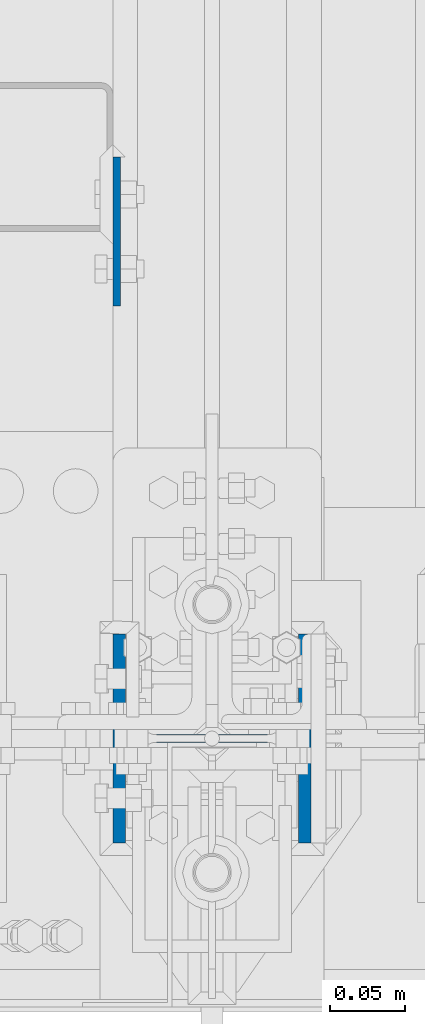
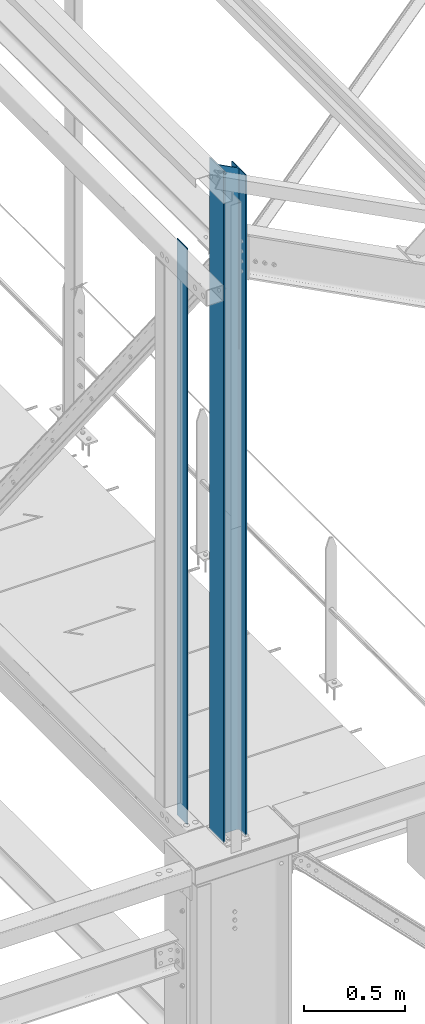
# One storey, part 2 of 496: 2 columns, 2 elements without a shape of their own.
"""IFC2X3 building model written with IfcOpenShell, lengths in millimetres."""

import ifcopenshell
import ifcopenshell.guid

model = None  # the IFC model being written
_history = None  # IfcOwnerHistory: only IFC2X3 demands one
_inside = {}  # id of a spatial element -> (the spatial element, [elements in it])
_under = {}  # id of a project, library or spatial element -> (it, [spatial elements below it])
_declared = {}  # id of a project -> (the project, [libraries it declares])
_typed = {}  # id of a type object -> (the type object, [elements of that type])
_made_of = {}  # id of a material, layer set ... -> (it, [elements and type objects made of it])


def new_model(schema):
    """Start an empty IFC model of exactly this schema.

    Asked for "IFC4X3", IfcOpenShell would pick the latest addendum, in which some entities
    have other attributes; the version numbers below select the first issue.
    IFC2X3 requires an IfcOwnerHistory on every rooted entity: one is made here for all.
    """
    global model, _history
    if schema == "IFC4X3":
        model = ifcopenshell.file(schema_version=(4, 3, 0, 0))
    else:
        model = ifcopenshell.file(schema=schema)
    _inside.clear()
    _under.clear()
    _declared.clear()
    _typed.clear()
    _made_of.clear()
    _history = None
    if model.schema == "IFC2X3":
        org = make("IfcOrganization", Name="unknown")
        user = make(
            "IfcPersonAndOrganization",
            ThePerson=make("IfcPerson", FamilyName="unknown"),
            TheOrganization=org,
        )
        app = make(
            "IfcApplication",
            ApplicationDeveloper=org,
            Version="unknown",
            ApplicationFullName="unknown",
            ApplicationIdentifier="unknown",
        )
        _history = make(
            "IfcOwnerHistory",
            OwningUser=user,
            OwningApplication=app,
            ChangeAction="ADDED",
            CreationDate=0,
        )
    return model


def make(cls, **values):
    """One entity of the class cls with the attributes given. An attribute that is None is left unset."""
    return model.create_entity(
        cls, **{name: value for name, value in values.items() if value is not None}
    )


def rooted(cls, **values):
    """An entity with a GlobalId (a new one), such as an element, a storey or a relation."""
    return make(cls, GlobalId=ifcopenshell.guid.new(), OwnerHistory=_history, **values)


def si_unit(unit_type, name, prefix=None):
    """IfcSIUnit, for example si_unit("LENGTHUNIT", "METRE", prefix="MILLI")."""
    return make("IfcSIUnit", UnitType=unit_type, Prefix=prefix, Name=name)


def assignment(units):
    """IfcUnitAssignment: the units of a project."""
    return None if units is None else make("IfcUnitAssignment", Units=units)


def point(xyz):
    """IfcCartesianPoint."""
    return None if xyz is None else make("IfcCartesianPoint", Coordinates=xyz)


def direction(xyz):
    """IfcDirection."""
    return None if xyz is None else make("IfcDirection", DirectionRatios=xyz)


def frame(location, z_axis=None, x_axis=None):
    """IfcAxis2Placement3D, a coordinate frame: its origin and axes. An axis left out is left unset."""
    return make(
        "IfcAxis2Placement3D",
        Location=point(location),
        Axis=direction(z_axis),
        RefDirection=direction(x_axis),
    )


def frame_2d(location, x_axis=None):
    """IfcAxis2Placement2D, a coordinate frame in the plane: its origin and x axis."""
    return make(
        "IfcAxis2Placement2D", Location=point(location), RefDirection=direction(x_axis)
    )


def origin_with_axes():
    """The frame at (0, 0, 0) with the z axis (0, 0, 1) and the x axis (1, 0, 0) written out."""
    return frame((0.0, 0.0, 0.0), z_axis=(0.0, 0.0, 1.0), x_axis=(1.0, 0.0, 0.0))


def origin_2d_with_axis():
    """The frame at (0, 0) in the plane with the x axis (1, 0) written out."""
    return frame_2d((0.0, 0.0), x_axis=(1.0, 0.0))


def place(relative_to, where):
    """IfcLocalPlacement: puts the frame where relative to a parent placement (None: the world)."""
    return make(
        "IfcLocalPlacement", PlacementRelTo=relative_to, RelativePlacement=where
    )


def context(
    kind, dimensions, precision=None, world=None, true_north=None, identifier=None
):
    """IfcGeometricRepresentationContext, for example the 3D "Model" context."""
    return make(
        "IfcGeometricRepresentationContext",
        ContextIdentifier=identifier,
        ContextType=kind,
        CoordinateSpaceDimension=dimensions,
        Precision=precision,
        WorldCoordinateSystem=world,
        TrueNorth=true_north,
    )


def subcontext(parent, identifier, kind, view, scale=None):
    """IfcGeometricRepresentationSubContext, for example "Body" below "Model"."""
    return make(
        "IfcGeometricRepresentationSubContext",
        ContextIdentifier=identifier,
        ContextType=kind,
        ParentContext=parent,
        TargetScale=scale,
        TargetView=view,
    )


def project(units=None, contexts=None):
    """IfcProject with its units and contexts."""
    return rooted(
        "IfcProject",
        Name="project",
        RepresentationContexts=contexts,
        UnitsInContext=assignment(units),
    )


def spatial(cls, under=None, at=None, **own):
    """A site, building, storey or space (cls), placed at a placement, below another one or the project."""
    s = rooted(cls, ObjectPlacement=at, **own)
    if under is not None:
        _under.setdefault(under.id(), (under, []))[1].append(s)
    return s


def profile(cls, at=None, kind="AREA", **sizes):
    """A parametric profile (cls). Its sizes go by their IFC names, for example OverallWidth=200.0."""
    return make(cls, ProfileType=kind, Position=at, **sizes)


def rectangle(**sizes):
    """IfcRectangleProfileDef."""
    return profile("IfcRectangleProfileDef", **sizes)


def i_section(**sizes):
    """IfcIShapeProfileDef."""
    return profile("IfcIShapeProfileDef", **sizes)


def extrude(swept, where, along, depth):
    """IfcExtrudedAreaSolid: the profile swept, set in the frame where, extruded along a direction by depth."""
    return make(
        "IfcExtrudedAreaSolid",
        SweptArea=swept,
        Position=where,
        ExtrudedDirection=direction(along),
        Depth=depth,
    )


def clip(a, b, op="DIFFERENCE"):
    """IfcBooleanClippingResult: the solid a cut by the half space b."""
    return make(
        "IfcBooleanClippingResult", Operator=op, FirstOperand=a, SecondOperand=b
    )


def halfspace(plane, agree):
    """IfcHalfSpaceSolid: all space on one side of the plane z = 0 of the frame plane."""
    return make(
        "IfcHalfSpaceSolid",
        BaseSurface=make("IfcPlane", Position=plane),
        AgreementFlag=agree,
    )


def shape(context_of_items, identifier, shape_type, items):
    """IfcShapeRepresentation: the items that make up one representation, for example the "Body"."""
    return make(
        "IfcShapeRepresentation",
        ContextOfItems=context_of_items,
        RepresentationIdentifier=identifier,
        RepresentationType=shape_type,
        Items=items,
    )


def material(Name=None, Category=None):
    """IfcMaterial."""
    return make("IfcMaterial", Name=Name, Category=Category)


def made_of(thing, what):
    """Note that an element or type object is made of a material, layer set ...; save() writes the relation."""
    if what is not None:
        _made_of.setdefault(what.id(), (what, []))[1].append(thing)
    return thing


def type_object(cls, material=None, **own):
    """A type object (cls), such as IfcWallType, which elements share."""
    return made_of(rooted(cls, **own), material)


def element(
    cls,
    number,
    at=None,
    inside=None,
    cuts=None,
    type_object=None,
    material=None,
    context=None,
    identifier="Body",
    shape_type=None,
    held_by="IfcProductDefinitionShape",
    body=None,
    shapes=None,
    **own,
):
    """One element of the class cls, such as IfcWall. Its Tag is "e" and its number.

    at: its placement. inside: the storey or other place that contains it. cuts: it is an
    opening in that element (IfcRelVoidsElement). A single representation is given by context,
    identifier, shape_type and body (its items); several are given by shapes. held_by: the class
    of the entity that holds the representations. save() writes the other relations.
    """
    e = rooted(cls, Tag="e%d" % number, ObjectPlacement=at, **own)
    if body is not None:
        shapes = [shape(context, identifier, shape_type, body)]
    if shapes is not None:
        e.Representation = make(held_by, Representations=shapes)
    if inside is not None:
        _inside.setdefault(inside.id(), (inside, []))[1].append(e)
    if cuts is not None:
        rooted(
            "IfcRelVoidsElement", RelatingBuildingElement=cuts, RelatedOpeningElement=e
        )
    if type_object is not None:
        _typed.setdefault(type_object.id(), (type_object, []))[1].append(e)
    return made_of(e, material)


def aggregate(whole, parts):
    """IfcRelAggregates: a whole, such as a stair, and the parts it consists of."""
    return rooted("IfcRelAggregates", RelatingObject=whole, RelatedObjects=parts)


def save(model, path):
    """Write the relations noted so far, then the file.

    IfcRelAggregates (storeys below a building ...), IfcRelContainedInSpatialStructure (elements
    in a storey), IfcRelDefinesByType, IfcRelAssociatesMaterial and IfcRelDeclares: one each for
    every whole, place, type object, material and project.
    """
    for whole, parts in _under.values():
        aggregate(whole, parts)
    for where, things in _inside.values():
        rooted(
            "IfcRelContainedInSpatialStructure",
            RelatedElements=things,
            RelatingStructure=where,
        )
    for kind, things in _typed.values():
        rooted("IfcRelDefinesByType", RelatedObjects=things, RelatingType=kind)
    for what, things in _made_of.values():
        rooted("IfcRelAssociatesMaterial", RelatedObjects=things, RelatingMaterial=what)
    for by, libraries in _declared.values():
        rooted("IfcRelDeclares", RelatingContext=by, RelatedDefinitions=libraries)
    model.write(path)


model = new_model("IFC2X3")

# Units and contexts
model_context = context("Model", 3, precision=1e-05, world=origin_with_axes())
body_context = subcontext(model_context, "Body", "Model", "MODEL_VIEW")
ifc_project = project(units=[si_unit("LENGTHUNIT", "METRE", prefix="MILLI"), si_unit("AREAUNIT", "SQUARE_METRE"), si_unit("VOLUMEUNIT", "CUBIC_METRE"), si_unit("MASSUNIT", "GRAM", prefix="KILO"), si_unit("TIMEUNIT", "SECOND"), si_unit("PLANEANGLEUNIT", "RADIAN"), si_unit("SOLIDANGLEUNIT", "STERADIAN"), si_unit("THERMODYNAMICTEMPERATUREUNIT", "DEGREE_CELSIUS"), si_unit("LUMINOUSINTENSITYUNIT", "LUMEN")], contexts=[model_context])

# Site, building, storey
site_placement = place(None, origin_with_axes())
site = spatial("IfcSite", under=ifc_project, at=site_placement, CompositionType="ELEMENT")
building_placement = place(site_placement, origin_with_axes())
building = spatial("IfcBuilding", under=site, at=building_placement, Name="Undefined", CompositionType="ELEMENT")
storey_placement = place(building_placement, origin_with_axes())
storey = spatial("IfcBuildingStorey", under=building, at=storey_placement, Name="Undefined", CompositionType="ELEMENT", Elevation=0.0)

# Assembly, column
assembly_1_placement = place(storey_placement, origin_with_axes())
assembly_1 = element("IfcElementAssembly", 1, at=assembly_1_placement, inside=storey, Name="MONTANT", AssemblyPlace="NOTDEFINED", PredefinedType="NOTDEFINED")
ifc_material_1 = material(Name="Undefined/S275-E28")
column_type_1 = type_object("IfcColumnType", Name="HEA140", PredefinedType="NOTDEFINED")
column_1_placement = place(assembly_1_placement, frame((12680.0, 0.0, 8560.0), z_axis=(0.0, 0.0, 1.0), x_axis=(-1.0, 0.0, 0.0)))
column_1 = element("IfcColumn", 2, at=column_1_placement, type_object=column_type_1, material=ifc_material_1, Name="MONTANT", ObjectType="HEA140", context=body_context, shape_type="Clipping", body=[
    clip(extrude(i_section(OverallWidth=140.0, OverallDepth=133.0, WebThickness=5.5, FlangeThickness=8.5, FilletRadius=12.0, at=origin_2d_with_axis()), frame((0.0, 0.0, 4053.83), z_axis=(0.0, 0.0, -1.0), x_axis=(0.0, 1.0, 0.0)), (0.0, 0.0, 1.0), 4053.83), halfspace(frame((-66.5, 70.0, 3972.97130380653), z_axis=(-0.463528461042155, -7.08866187195592e-09, 0.886082031080583), x_axis=(0.886082031080583, 0.0, 0.463528461042155)), False)),
])
aggregate(assembly_1, [column_1])

assembly_2_placement = place(storey_placement, origin_with_axes())
assembly_2 = element("IfcElementAssembly", 3, at=assembly_2_placement, inside=storey, Name="MONTANT", AssemblyPlace="NOTDEFINED", PredefinedType="NOTDEFINED")
ifc_material_2 = material(Name="Undefined/S235-E24")
column_type_2 = type_object("IfcColumnType", PredefinedType="NOTDEFINED")
column_2_placement = place(assembly_2_placement, frame((12616.000107016, 339.9999987911, 8450.0), z_axis=(0.0, 0.0, 1.0), x_axis=(0.0, -1.0, 0.0)))
column_2 = element("IfcColumn", 4, at=column_2_placement, type_object=column_type_2, material=ifc_material_2, context=body_context, shape_type="SweptSolid", body=[
    extrude(rectangle(XDim=5.0, YDim=100.0, at=origin_2d_with_axis()), frame((0.0, 0.0, 3470.0), z_axis=(0.0, 0.0, -1.0), x_axis=(0.0, 1.0, 0.0)), (0.0, 0.0, 1.0), 3470.0),
])
aggregate(assembly_2, [column_2])

save(model, "model.ifc")
